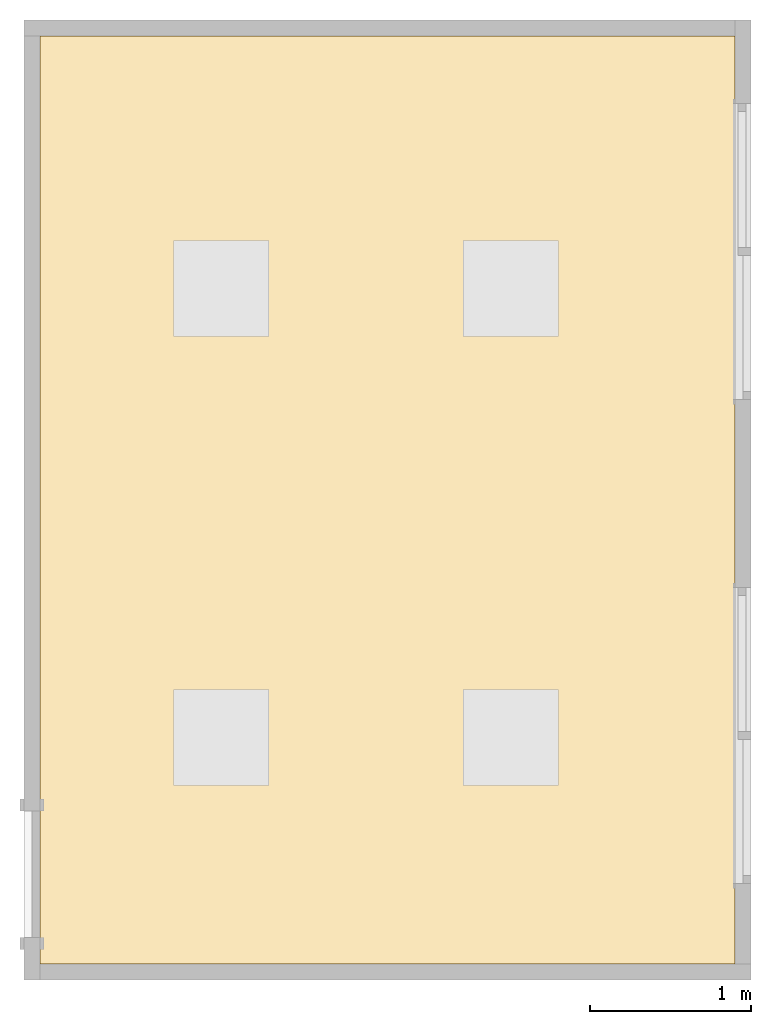
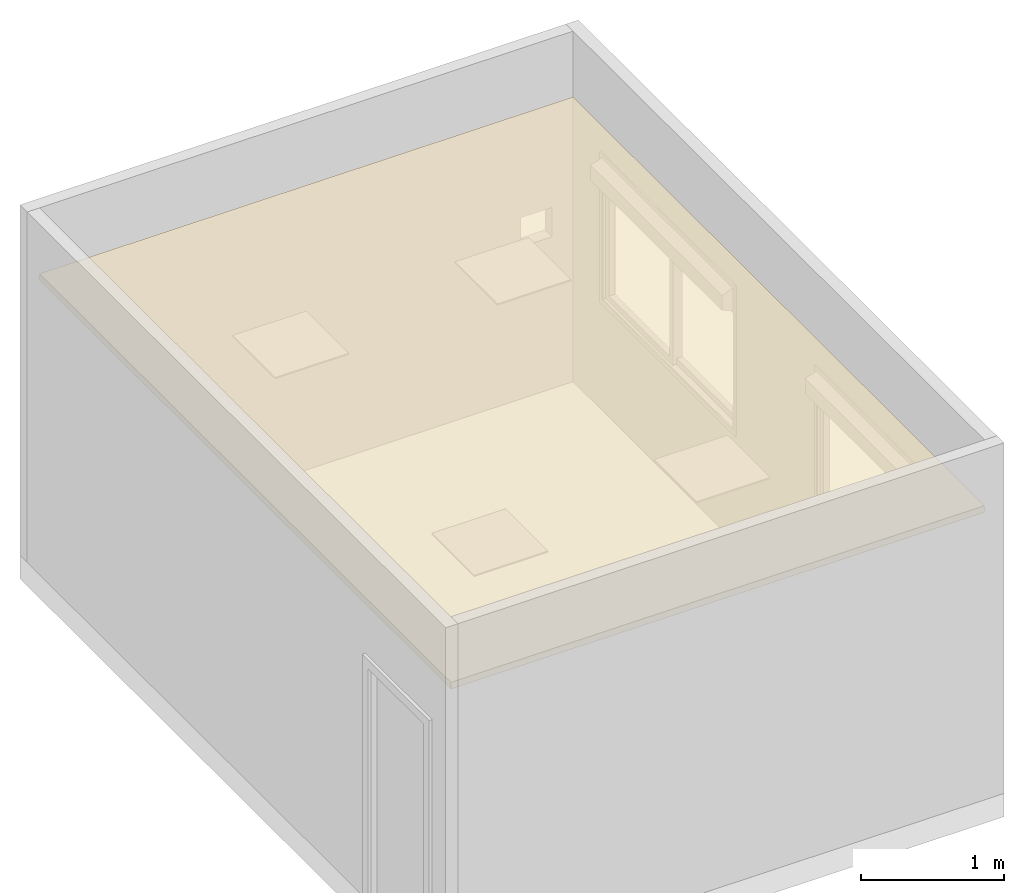
# One storey, part 2 of 3: 1 covering.
"""IFC2X3 building model written with IfcOpenShell, lengths in millimetres."""

from ifc_helpers import new_model, entity, si_unit, converted_unit, derived_unit, direction, frame, origin, place, context, subcontext, project, spatial, faceted_brep, material, layer, layer_set, layer_usage, type_object, element, save


model = new_model("IFC2X3")

# Units and contexts
model_context = context("Model", 3, precision=0.01, world=origin(), true_north=direction((6.12303176911189e-17, 1.0)))
body_context = subcontext(model_context, "Body", "Model", "MODEL_VIEW")
ifc_project = project(units=[si_unit("LENGTHUNIT", "METRE", prefix="MILLI"), si_unit("AREAUNIT", "SQUARE_METRE"), si_unit("VOLUMEUNIT", "CUBIC_METRE"), converted_unit("PLANEANGLEUNIT", "DEGREE", entity("IfcRatioMeasure", 0.0174532925199433), si_unit("PLANEANGLEUNIT", "RADIAN"), dimensions=[0, 0, 0, 0, 0, 0, 0]), si_unit("MASSUNIT", "GRAM", prefix="KILO"), derived_unit("MASSDENSITYUNIT", [(si_unit("MASSUNIT", "GRAM", prefix="KILO"), 1), (si_unit("LENGTHUNIT", "METRE"), -3)]), derived_unit("MOMENTOFINERTIAUNIT", [(si_unit("LENGTHUNIT", "METRE"), 4)]), si_unit("TIMEUNIT", "SECOND"), si_unit("FREQUENCYUNIT", "HERTZ"), si_unit("THERMODYNAMICTEMPERATUREUNIT", "DEGREE_CELSIUS"), derived_unit("THERMALTRANSMITTANCEUNIT", [(si_unit("MASSUNIT", "GRAM", prefix="KILO"), 1), (si_unit("THERMODYNAMICTEMPERATUREUNIT", "KELVIN"), -1), (si_unit("TIMEUNIT", "SECOND"), -3)]), derived_unit("VOLUMETRICFLOWRATEUNIT", [(si_unit("LENGTHUNIT", "METRE"), 3), (si_unit("TIMEUNIT", "SECOND"), -1)]), si_unit("ELECTRICCURRENTUNIT", "AMPERE"), si_unit("ELECTRICVOLTAGEUNIT", "VOLT"), si_unit("POWERUNIT", "WATT"), si_unit("FORCEUNIT", "NEWTON", prefix="KILO"), si_unit("ILLUMINANCEUNIT", "LUX"), si_unit("LUMINOUSFLUXUNIT", "LUMEN"), si_unit("LUMINOUSINTENSITYUNIT", "CANDELA"), derived_unit("USERDEFINED", [(si_unit("MASSUNIT", "GRAM", prefix="KILO"), -1), (si_unit("LENGTHUNIT", "METRE"), -2), (si_unit("TIMEUNIT", "SECOND"), 3), (si_unit("LUMINOUSFLUXUNIT", "LUMEN"), 1)]), derived_unit("LINEARVELOCITYUNIT", [(si_unit("LENGTHUNIT", "METRE"), 1), (si_unit("TIMEUNIT", "SECOND"), -1)]), si_unit("PRESSUREUNIT", "PASCAL"), derived_unit("USERDEFINED", [(si_unit("LENGTHUNIT", "METRE"), -2), (si_unit("MASSUNIT", "GRAM", prefix="KILO"), 1), (si_unit("TIMEUNIT", "SECOND"), -2)]), derived_unit("LINEARFORCEUNIT", [(si_unit("MASSUNIT", "GRAM", prefix="KILO"), 1), (si_unit("LENGTHUNIT", "METRE"), 1), (si_unit("TIMEUNIT", "SECOND"), -2), (si_unit("LENGTHUNIT", "METRE"), -1)]), derived_unit("PLANARFORCEUNIT", [(si_unit("MASSUNIT", "GRAM", prefix="KILO"), 1), (si_unit("LENGTHUNIT", "METRE"), 1), (si_unit("TIMEUNIT", "SECOND"), -2), (si_unit("LENGTHUNIT", "METRE"), -2)])], contexts=[model_context])

# Site, building, storey
site_placement = place(None, origin())
site = spatial("IfcSite", under=ifc_project, at=site_placement, CompositionType="ELEMENT")
building_placement = place(site_placement, origin())
building = spatial("IfcBuilding", under=site, at=building_placement, CompositionType="ELEMENT")
storey_placement = place(building_placement, origin())
storey = spatial("IfcBuildingStorey", under=building, at=storey_placement, Name="Niveau 1", CompositionType="ELEMENT", Elevation=0.0)

# Covering
ifc_material_1 = material()
ifc_layer_1 = layer(ifc_material_1, 45.0)
ifc_material_2 = material(Name="Plaque de mur de gypse")
ifc_layer_2 = layer(ifc_material_2, 12.0)
ifc_layer_set = layer_set([ifc_layer_1, ifc_layer_2])
ifc_layer_usage = layer_usage(ifc_layer_set, "AXIS3", "POSITIVE", 0.0)
covering_type = type_object("IfcCoveringType", PredefinedType="CEILING")
covering_placement = place(storey_placement, frame((-2354.56093937368, -2012.04742444567, 2380.0)))
element("IfcCovering", 1, at=covering_placement, inside=storey, type_object=covering_type, material=ifc_layer_usage, PredefinedType="CEILING", context=body_context, shape_type="Brep", body=[
    faceted_brep([(0.0, 5770.0, 57.0), (0.0, 0.0, 57.0), (4320.0, 0.0, 57.0), (4320.0, 5770.0, 57.0), (0.0, 0.0, 0.0), (0.0, 5770.0, 0.0), (4320.0, 5770.0, 0.0), (4320.0, 0.0, 0.0), (1425.0, 4497.50000000001, 0.0), (830.0, 4497.50000000001, 0.0), (830.0, 3902.50000000001, 0.0), (1425.0, 3902.50000000001, 0.0), (3225.0, 4497.50000000001, 0.0), (2630.0, 4497.50000000001, 0.0), (2630.0, 3902.50000000001, 0.0), (3225.0, 3902.50000000001, 0.0), (1425.0, 1705.0, 0.0), (830.0, 1705.0, 0.0), (830.0, 1110.0, 0.0), (1425.0, 1110.0, 0.0), (3225.0, 1705.0, 0.0), (2630.0, 1705.0, 0.0), (2630.0, 1110.0, 0.0), (3225.0, 1110.0, 0.0), (830.0, 4497.50000000001, 10.0), (1425.0, 4497.50000000001, 10.0), (1425.0, 3902.50000000001, 10.0), (830.0, 3902.50000000001, 10.0), (2630.0, 4497.50000000001, 10.0), (3225.0, 4497.50000000001, 10.0), (3225.0, 3902.50000000001, 10.0), (2630.0, 3902.50000000001, 10.0), (830.0, 1705.0, 10.0), (1425.0, 1705.0, 10.0), (1425.0, 1110.0, 10.0), (830.0, 1110.0, 10.0), (2630.0, 1705.0, 10.0), (3225.0, 1705.0, 10.0), (3225.0, 1110.0, 10.0), (2630.0, 1110.0, 10.0)], [[[0, 1, 2, 3]], [[4, 5, 6, 7], [8, 9, 10, 11], [12, 13, 14, 15], [16, 17, 18, 19], [20, 21, 22, 23]], [[1, 0, 5, 4]], [[2, 1, 4, 7]], [[3, 2, 7, 6]], [[0, 3, 6, 5]], [[24, 25, 26, 27]], [[25, 24, 9, 8]], [[26, 25, 8, 11]], [[24, 27, 10, 9]], [[27, 26, 11, 10]], [[28, 29, 30, 31]], [[29, 28, 13, 12]], [[30, 29, 12, 15]], [[28, 31, 14, 13]], [[31, 30, 15, 14]], [[32, 33, 34, 35]], [[33, 32, 17, 16]], [[34, 33, 16, 19]], [[32, 35, 18, 17]], [[35, 34, 19, 18]], [[36, 37, 38, 39]], [[37, 36, 21, 20]], [[38, 37, 20, 23]], [[36, 39, 22, 21]], [[39, 38, 23, 22]]]),
])

save(model, "model.ifc")
